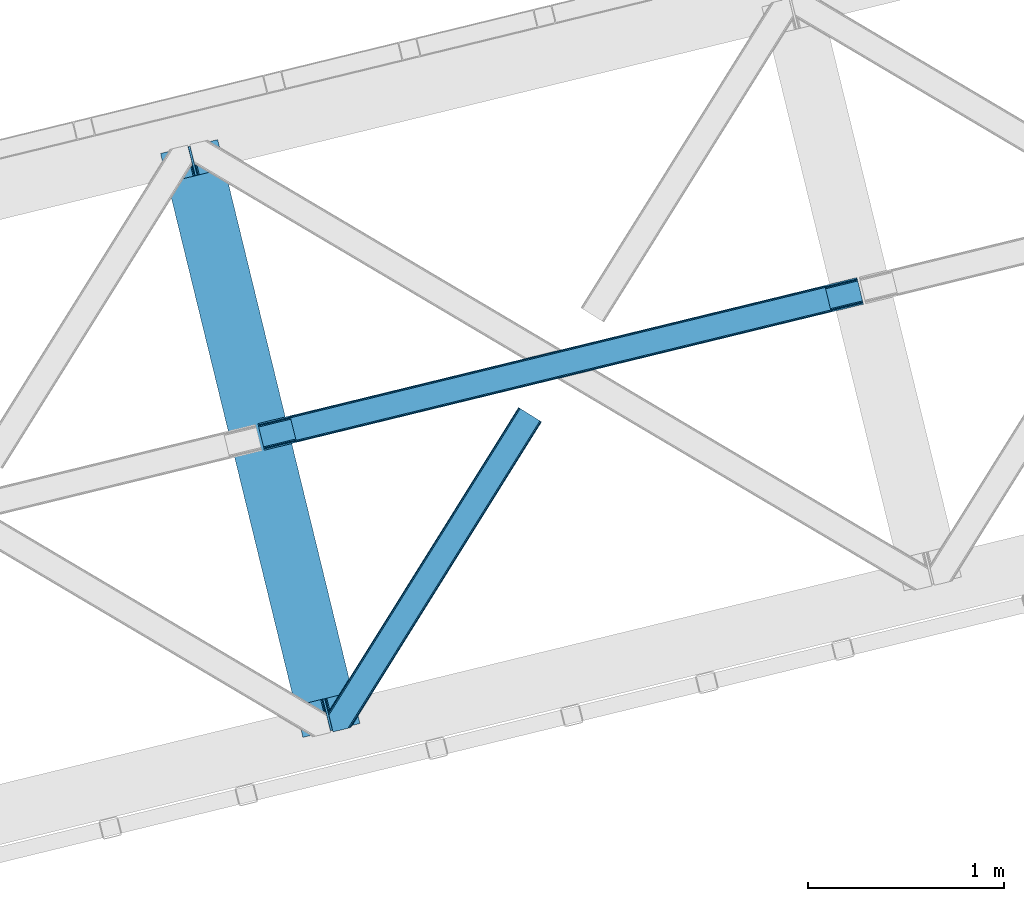
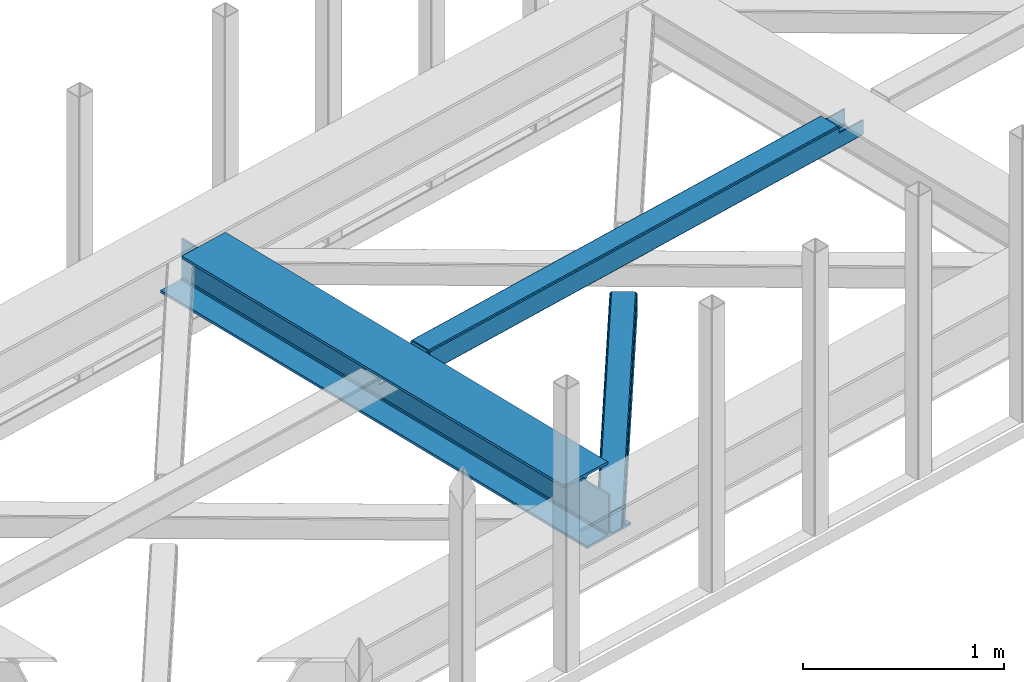
# One storey, part 46 of 67: 2 beams, 1 member.
"""IFC4 building model written with IfcOpenShell, lengths in millimetres."""

from ifc_helpers import new_model, entity, si_unit, converted_unit, derived_unit, direction, frame, origin, place, context, subcontext, project, spatial, triangles, polygons, material, type_object, element, save


model = new_model("IFC4")

# Units and contexts
model_context = context("Model", 3, precision=0.01, world=origin(), true_north=direction((6.12303176911189e-17, 1.0)))
plan_context = context("Plan", 3, precision=0.01, world=origin(), true_north=direction((6.12303176911189e-17, 1.0)))
body_context = subcontext(model_context, "Body", "Model", "MODEL_VIEW")
ifc_project = project(units=[si_unit("LENGTHUNIT", "METRE", prefix="MILLI"), si_unit("AREAUNIT", "SQUARE_METRE"), si_unit("VOLUMEUNIT", "CUBIC_METRE"), converted_unit("PLANEANGLEUNIT", "DEGREE", entity("IfcRatioMeasure", 0.0174532925199433), si_unit("PLANEANGLEUNIT", "RADIAN"), dimensions=[0, 0, 0, 0, 0, 0, 0]), si_unit("MASSUNIT", "GRAM", prefix="KILO"), derived_unit("MASSDENSITYUNIT", [(si_unit("MASSUNIT", "GRAM", prefix="KILO"), 1), (si_unit("LENGTHUNIT", "METRE"), -3)]), derived_unit("MOMENTOFINERTIAUNIT", [(si_unit("LENGTHUNIT", "METRE"), 4)]), si_unit("TIMEUNIT", "SECOND"), si_unit("FREQUENCYUNIT", "HERTZ"), si_unit("THERMODYNAMICTEMPERATUREUNIT", "DEGREE_CELSIUS"), derived_unit("THERMALTRANSMITTANCEUNIT", [(si_unit("MASSUNIT", "GRAM", prefix="KILO"), 1), (si_unit("THERMODYNAMICTEMPERATUREUNIT", "KELVIN"), -1), (si_unit("TIMEUNIT", "SECOND"), -3)]), derived_unit("VOLUMETRICFLOWRATEUNIT", [(si_unit("LENGTHUNIT", "METRE"), 3), (si_unit("TIMEUNIT", "SECOND"), -1)]), derived_unit("MASSFLOWRATEUNIT", [(si_unit("MASSUNIT", "GRAM", prefix="KILO"), 1), (si_unit("TIMEUNIT", "SECOND"), -1)]), derived_unit("ROTATIONALFREQUENCYUNIT", [(si_unit("TIMEUNIT", "SECOND"), -1)]), si_unit("ELECTRICCURRENTUNIT", "AMPERE"), si_unit("ELECTRICVOLTAGEUNIT", "VOLT"), si_unit("POWERUNIT", "WATT"), si_unit("FORCEUNIT", "NEWTON", prefix="KILO"), si_unit("ILLUMINANCEUNIT", "LUX"), si_unit("LUMINOUSFLUXUNIT", "LUMEN"), si_unit("LUMINOUSINTENSITYUNIT", "CANDELA"), derived_unit("USERDEFINED", [(si_unit("MASSUNIT", "GRAM", prefix="KILO"), -1), (si_unit("LENGTHUNIT", "METRE"), -2), (si_unit("TIMEUNIT", "SECOND"), 3), (si_unit("LUMINOUSFLUXUNIT", "LUMEN"), 1)]), derived_unit("LINEARVELOCITYUNIT", [(si_unit("LENGTHUNIT", "METRE"), 1), (si_unit("TIMEUNIT", "SECOND"), -1)]), si_unit("PRESSUREUNIT", "PASCAL"), derived_unit("USERDEFINED", [(si_unit("LENGTHUNIT", "METRE"), -2), (si_unit("MASSUNIT", "GRAM", prefix="KILO"), 1), (si_unit("TIMEUNIT", "SECOND"), -2)]), derived_unit("LINEARFORCEUNIT", [(si_unit("MASSUNIT", "GRAM", prefix="KILO"), 1), (si_unit("LENGTHUNIT", "METRE"), 1), (si_unit("TIMEUNIT", "SECOND"), -2), (si_unit("LENGTHUNIT", "METRE"), -1)]), derived_unit("PLANARFORCEUNIT", [(si_unit("MASSUNIT", "GRAM", prefix="KILO"), 1), (si_unit("LENGTHUNIT", "METRE"), 1), (si_unit("TIMEUNIT", "SECOND"), -2), (si_unit("LENGTHUNIT", "METRE"), -2)])], contexts=[model_context, plan_context])

# Site, building, storey
site_placement = place(None, origin())
site = spatial("IfcSite", under=ifc_project, at=site_placement, CompositionType="ELEMENT")
building_placement = place(site_placement, origin())
building = spatial("IfcBuilding", under=site, at=building_placement, CompositionType="ELEMENT")
storey_placement = place(building_placement, frame((0.0, 0.0, 19800.0)))
storey = spatial("IfcBuildingStorey", under=building, at=storey_placement, CompositionType="ELEMENT", Elevation=19800.0)

# Beams
ifc_material = material(Name="Metal painted (White)")
beam_type = type_object("IfcBeamType", PredefinedType="BEAM")
beam_1_placement = place(storey_placement, frame((-18024.6116349048, 13401.2394300083, 3807.02022389142)))
element("IfcBeam", 1, at=beam_1_placement, inside=storey, type_object=beam_type, material=ifc_material, ObjectType="Steel Beam", PredefinedType="BEAM", context=body_context, shape_type="Tessellation", body=[
    polygons([(1018.1664837833, 71.0478278971021, 15.5000000000008), (1018.1664837833, 71.0478278971021, 0.0), (291.465617442448, 3052.25531830422, 0.0), (291.465617442448, 3052.25531830422, 15.5000000000008), (894.779372399336, 40.9709140873291, 15.5000000000008), (168.078506058485, 3022.17840449444, 15.5000000000008), (888.087028625368, 39.3395844888221, 16.8701684148028), (161.38616228452, 3020.54707489593, 16.8701684148028), (882.413533524757, 37.956610033654, 20.7720779386434), (155.712667183904, 3019.16410044077, 20.7720779386434), (878.622625296178, 37.0325360459162, 26.6116982174338), (151.921758955329, 3018.24002645303, 26.6116982174338), (877.291435352781, 36.7080444135007, 33.500000000001), (150.59056901193, 3017.91553482062, 33.500000000001), (140.875048430516, 3015.54727389071, 33.500000000001), (140.875048430516, 3015.54727389071, 259.000000000002), (150.59056901193, 3017.91553482062, 259.000000000002), (8.66293703438714e-12, 2981.20749040711, 0.0), (6.49720277579036e-12, 2981.20749040711, 15.4999999999965), (123.38711138397, 3011.28440421689, 15.5000000000008), (130.079455157935, 3012.91573381539, 16.8701684147984), (135.752950258553, 3014.29870827056, 20.7720779386434), (139.543858487119, 3015.22278225829, 26.6116982174294), (877.291435352781, 36.7080444135007, 259.000000000002), (867.575914771367, 34.3397834835992, 259.000000000002), (867.575914771369, 34.3397834835992, 33.500000000001), (866.24472482797, 34.0152918511837, 26.6116982174294), (862.453816599406, 33.0912178634546, 20.7720779386434), (856.780321498788, 31.7082434082822, 16.8701684147984), (850.087977724821, 30.0769138097752, 15.5000000000008), (726.700866340857, 0.0, 15.4999999999965), (726.700866340857, 0.0, 0.0), (838.124523615912, 197.385937999183, 259.069791973884), (186.469722099971, 2870.72539801219, 259.000000000002), (186.693115201822, 2869.80895360721, 259.617303331124), (186.705504045448, 2869.75812937344, 266.500003008253), (837.979344808145, 197.981416001708, 266.500002998871), (837.979694928899, 197.979979696973, 260.000004007589), (828.499586345876, 194.645865944434, 259.006343171919), (828.276216326111, 195.562317481914, 259.617303331124), (828.263827482484, 195.613141715689, 266.500003008253), (176.989986719784, 2867.38985508742, 266.500002998871), (176.989636599034, 2867.39129139215, 260.000004007589), (176.844830940692, 2867.98534020594, 259.07612046749), (176.754201518561, 2868.35713708228, 259.000000000002), (839.310832678068, 198.304685446393, 273.388305639783), (843.10110926677, 199.231350618306, 279.227924098781), (848.774180214294, 200.616065081981, 283.12983240061), (855.46637189544, 202.248018612798, 284.500000377228), (978.853400583278, 232.325271667905, 284.500000138971), (978.851730776626, 232.332121736639, 299.999995328161), (687.386308679356, 161.283492472598, 299.999995890962), (687.387978486005, 161.276642403863, 284.500000701776), (810.775007173849, 191.353895458974, 284.500000463519), (817.467494070001, 192.984637925557, 283.129832461069), (823.141405718761, 194.365903570083, 279.227924137322), (826.93294050574, 195.287407219375, 273.388305663684), (175.658498849859, 2867.06658564273, 273.388305639788), (171.868222261176, 2866.13992047082, 279.227924098781), (166.195151313642, 2864.75520600715, 283.129832400619), (159.502959632499, 2863.12325247633, 284.500000377228), (36.115930944662, 2833.04599942122, 284.500000138971), (36.1176007513137, 2833.03914935249, 299.999995328161), (327.583022848584, 2904.08777861653, 299.999995890962), (327.581353041935, 2904.09462868526, 284.500000701776), (204.19432435409, 2874.01737563015, 284.500000463519), (197.501837457939, 2872.38663316357, 283.12983246106), (191.827925809187, 2871.00536751904, 279.227924137322), (188.036391022187, 2870.08386386975, 273.388305663684)], [[[1, 2, 3, 4]], [[5, 1, 4, 6]], [[7, 5, 6, 8]], [[9, 7, 8, 10]], [[11, 9, 10, 12]], [[13, 11, 12, 14]], [[15, 16, 17, 14, 12, 10, 8, 6, 4, 3, 18, 19, 20, 21, 22, 23]], [[13, 24, 25, 26, 27, 28, 29, 30, 31, 32, 2, 1, 5, 7, 9, 11]], [[2, 32, 18, 3]], [[32, 31, 19, 18]], [[31, 30, 20, 19]], [[27, 26, 15, 23]], [[28, 27, 23, 22]], [[29, 28, 22, 21]], [[30, 29, 21, 20]], [[33, 24, 13, 14, 17, 34, 35, 36, 37, 38]], [[25, 39, 40, 41, 42, 43, 44, 16, 15, 26]], [[39, 25, 24, 33]], [[45, 34, 17, 16]], [[41, 40, 38, 37, 46, 47, 48, 49, 50, 51, 52, 53, 54, 55, 56, 57]], [[42, 58, 59, 60, 61, 62, 63, 64, 65, 66, 67, 68, 69, 36, 35, 43]], [[46, 37, 36, 69]], [[47, 46, 69, 68]], [[48, 47, 68, 67]], [[49, 48, 67, 66]], [[50, 49, 66, 65]], [[51, 50, 65, 64]], [[52, 51, 64, 63]], [[53, 52, 63, 62]], [[54, 53, 62, 61]], [[55, 54, 61, 60]], [[56, 55, 60, 59]], [[57, 56, 59, 58]], [[41, 57, 58, 42]]], closed=False),
])
beam_2_placement = place(storey_placement, frame((-17527.8754833013, 14867.3373780409, 3967.02022389142)))
element("IfcBeam", 2, at=beam_2_placement, inside=storey, type_object=beam_type, material=ifc_material, ObjectType="Steel Beam", PredefinedType="BEAM", context=body_context, shape_type="Tessellation", body=[
    polygons([(31.1823923917571, 8.09507685195891, 17.8030399336114), (31.4978703677165, 6.80086440699001, 24.4999999999988), (3089.94374939708, 752.32940514057, 24.4999999999988), (3089.62827142111, 753.623617585539, 17.8030399336114), (30.2839871259056, 11.7806820741885, 12.1256313292298), (3088.72986615526, 757.309222807769, 12.1256313292298), (28.9394286278213, 17.2965800886753, 8.33210818105214), (3087.38530765717, 762.825120822256, 8.33210818105214), (27.353413740384, 23.8030254244661, 7.00000000000274), (3085.79929276974, 769.331566158046, 7.00000000000274), (4.21622439083043, 118.720708051131, 8.33210818105214), (5.8022392782634, 112.214262715343, 7.00000000000274), (3064.24811830762, 857.742803448923, 7.00000000000274), (3062.66210342018, 864.249248784712, 8.33210818105214), (2.87166589274607, 124.236606065618, 12.1256313292342), (3061.3175449221, 869.765146799198, 12.1256313292342), (1.9732606268946, 127.922211287848, 17.8030399336114), (3060.41913965625, 873.450752021428, 17.8030399336114), (1.65778265093302, 129.216423732814, 24.4999999999988), (3060.10366168029, 874.744964466399, 24.4999999999988), (33.1556530186517, -2.16573425859679e-12, 17.5000000000004), (33.1556530186517, -2.16573425859679e-12, 99.499999999999), (31.4978703677165, 6.80086440699001, 99.499999999999), (1.65778265093302, 129.216423732814, 99.499999999999), (2.16573425859679e-12, 136.017288139807, 99.499999999999), (2.16573425859679e-12, 136.017288139807, 17.5000000000004), (0.315477975961585, 134.723075694836, 10.803039933613), (1.21388324181306, 131.037470472612, 5.12563132923143), (2.55844173989742, 125.521572458121, 1.33210818105373), (4.14445662733471, 119.015127122331, 0.0), (29.011196391317, 17.0021610174739, 0.0), (30.5972112787521, 10.4957156816831, 1.33210818105373), (31.9417697768386, 4.97981766719418, 5.12563132923576), (32.8401750426901, 1.29421244496674, 10.803039933613), (3058.44587902937, 881.545828873391, 17.5000000000004), (3058.44587902937, 881.545828873391, 99.499999999999), (3060.1036616803, 874.744964466399, 99.499999999999), (3089.94374939708, 752.329405140575, 99.499999999999), (3091.60153204801, 745.528540733585, 99.499999999999), (3091.60153204801, 745.528540733585, 17.5000000000004), (3091.28605407205, 746.822753178554, 10.803039933613), (3090.3876488062, 750.508358400777, 5.12563132923576), (3089.04309030812, 756.024256415266, 1.33210818105373), (3087.45707542068, 762.530701751061, 0.0), (3062.5903356567, 864.543667855915, 0.0), (3061.00432076926, 871.050113191704, 1.33210818105373), (3059.65976227118, 876.566011206193, 5.12563132923143), (3058.76135700532, 880.251616428422, 10.803039933613), (2925.75994180942, 712.307865540883, 115.5000123926), (2925.81630989428, 712.321604759499, 100.117303289864), (2926.72300362931, 712.542621518195, 99.499999999999), (194.71860658079, 46.5876811586714, 99.5063429816656), (195.631369831906, 46.8101414944987, 100.117301735448), (195.690168193625, 46.8244741223546, 115.5), (2928.38078628024, 705.741757111203, 99.499999999999), (2927.47422618798, 705.520772937694, 100.117303484932), (2927.41464342032, 705.506249905351, 122.500007895425), (197.345360928041, 40.0229783796023, 122.500002534479), (197.338587096728, 40.0213271441435, 100.500009163303), (196.74820519572, 39.8773799905065, 99.5697919021647), (2896.88292546721, 834.958147714713, 99.5063429816656), (2895.97381660773, 834.736577551997, 100.117299778624), (2895.91744852288, 834.722838333381, 115.50000888136), (165.850080476841, 169.240033448181, 115.5), (165.840462203332, 169.237688832039, 100.50000941238), (165.250325295035, 169.093836777331, 99.5761204674868), (2894.85332685228, 841.668448882883, 99.5697919021647), (163.220745767762, 175.804071762182, 99.499999999999), (164.133244938506, 176.026503182397, 100.117301984524), (164.189439987621, 176.040201208966, 122.500002796667), (2894.25631754637, 841.522886341462, 122.500003994045), (2894.26642083519, 841.525349756029, 100.500018741102), (2894.56843170075, 840.227853719298, 129.196959150505), (2895.46176722634, 836.541012377604, 134.874360354937), (2896.8030582304, 831.024317672799, 138.667878733795), (2898.38810531641, 824.517636364724, 139.999985502214), (2923.25885436334, 722.505647815414, 139.999991354283), (2924.84634848092, 715.999563150009, 138.667885332354), (2926.19460804136, 710.484567539777, 134.874367586349), (2927.09837274857, 706.800269072827, 129.196966804773), (2925.44675217772, 713.602635936897, 122.196975799125), (2924.54298747051, 717.286934403856, 127.874376580702), (2923.19472791008, 722.801930014081, 131.667894326702), (2921.60723379249, 729.308014679486, 133.000000348631), (2900.05258461849, 817.718404755554, 132.999995276841), (2898.46753753248, 824.22508606363, 131.667888508414), (2897.12624652841, 829.741780768439, 127.874370129564), (2896.23291100282, 833.428622110128, 122.196968925133), (164.878528418698, 169.003207355192, 99.499999999999), (193.131726453727, 57.3201898040377, 131.667891818946), (191.545711566292, 63.8266351398307, 133.0), (194.476284951809, 51.8042917895488, 127.874368670764), (195.374690217663, 48.1186865673235, 122.196960066391), (169.994537104169, 152.237872430705, 133.0), (166.165558452801, 167.945821003215, 122.196960066391), (167.063963718652, 164.260215780989, 127.874368670764), (168.408522216734, 158.7443177665, 131.667891818946), (197.031411944058, 41.3175635421116, 129.196961104604), (196.136488323051, 45.0040174738959, 134.874366301861), (194.7942441573, 50.5204796458664, 138.667887185257), (193.209023953569, 57.0271186991972, 139.999994588639), (168.341882306926, 159.039986838386, 139.999994981919), (166.755021471176, 165.546225960032, 138.667887628704), (165.408105180718, 171.061549222925, 134.874366787843), (164.506189230952, 174.746298656824, 129.196961619)], [[[1, 2, 3, 4]], [[5, 1, 4, 6]], [[7, 5, 6, 8]], [[9, 7, 8, 10]], [[11, 12, 13, 14]], [[15, 11, 14, 16]], [[17, 15, 16, 18]], [[19, 17, 18, 20]], [[12, 9, 10, 13]], [[21, 22, 23, 2, 1, 5, 7, 9, 12, 11, 15, 17, 19, 24, 25, 26, 27, 28, 29, 30, 31, 32, 33, 34]], [[35, 36, 37, 20, 18, 16, 14, 13, 10, 8, 6, 4, 3, 38, 39, 40, 41, 42, 43, 44, 45, 46, 47, 48]], [[49, 50, 51, 38, 3, 2, 23, 52, 53, 54]], [[55, 39, 38, 51]], [[39, 55, 56, 57, 58, 59, 60, 22, 21, 40]], [[32, 31, 44, 43]], [[33, 32, 43, 42]], [[34, 33, 42, 41]], [[21, 34, 41, 40]], [[31, 30, 45, 44]], [[27, 26, 35, 48]], [[28, 27, 48, 47]], [[29, 28, 47, 46]], [[30, 29, 46, 45]], [[20, 37, 61, 62, 63, 64, 65, 66, 24, 19]], [[67, 36, 35, 26, 25, 68, 69, 70, 71, 72]], [[36, 67, 61, 37]], [[72, 71, 73, 74, 75, 76, 77, 78, 79, 80, 57, 56, 50, 49, 81, 82, 83, 84, 85, 86, 87, 88, 63, 62]], [[60, 52, 23, 22]], [[25, 24, 89, 68]], [[90, 91, 84, 83]], [[92, 90, 83, 82]], [[93, 92, 82, 81]], [[54, 93, 81, 49]], [[94, 85, 84, 91]], [[95, 64, 63, 88]], [[96, 95, 88, 87]], [[97, 96, 87, 86]], [[94, 97, 86, 85]], [[65, 64, 95, 96, 97, 94, 91, 90, 92, 93, 54, 53, 59, 58, 98, 99, 100, 101, 102, 103, 104, 105, 70, 69]], [[98, 58, 57, 80]], [[99, 98, 80, 79]], [[100, 99, 79, 78]], [[101, 100, 78, 77]], [[77, 76, 102, 101]], [[103, 102, 76, 75]], [[104, 103, 75, 74]], [[105, 104, 74, 73]], [[70, 105, 73, 71]]], closed=False),
])

# Member
member_type = type_object("IfcMemberType", PredefinedType="BRACE")
member_placement = place(storey_placement, frame((-17168.7764556885, 13429.4407470703, 3822.99993896484)))
element("IfcMember", 3, at=member_placement, inside=storey, type_object=member_type, ObjectType="Steel Horizontal Brace", PredefinedType="BRACE", context=body_context, shape_type="Tessellation", body=[
    triangles([(986.15143432617, 1647.42967529297, 0.0), (1075.22041625976, 1591.82725524902, 0.0), (119.789199829102, 259.603921508788, 0.0), (154.548706054688, 117.003323364257, 0.0), (115.903390502928, 275.544808959959, 4.52065429687718), (117.571893310545, 268.698715209961, 1.33247680664135), (158.434515380857, 101.062435913085, 4.52065429687718), (156.76601257324, 107.908529663086, 1.33247680664135), (114.825549316403, 275.743634033202, 5.52059326172093), (115.126693725586, 275.922692871092, 5.35316162109302), (158.127557373045, 99.1206939697258, 5.27642211914281), (115.440628051758, 276.107565307617, 5.18107910156323), (158.231039428709, 99.7776306152336, 5.02062377929906), (158.183367919919, 99.4811370849602, 5.13457031250073), (115.540621948239, 276.16686401367, 5.12526855468968), (115.682473754881, 275.92036743164, 4.88574829101708), (158.334521484372, 100.433404541014, 4.76482543945531), (158.032214355466, 98.4928253173821, 5.52059326172093), (1085.71744995117, 1585.27416687012, 5.12526855468968), (1080.90030212402, 1588.27979736328, 1.33247680664135), (1088.93469543457, 1583.26498718262, 10.8039916992202), (114.209307861325, 21.8533172607422, 10.8039916992202), (109.46541137695, 20.6964111328125, 5.52059326172093), (1090.06485900879, 1582.55921630859, 17.5012573242202), (116.061520385741, 22.304452514647, 17.5012573242202), (6.75075073241896, 102.619317626952, 5.52059326172093), (31.3608764648416, 1.65803833007703, 5.52059326172093), (1090.06485900879, 1582.55921630859, 122.499499511719), (116.061520385741, 22.304452514647, 122.499499511719), (1088.93469543457, 1583.26498718262, 129.196765136719), (114.209307861325, 21.8533172607422, 129.196765136719), (1085.71744995117, 1585.27416687012, 134.87548828125), (108.931723022459, 20.566186523436, 134.87548828125), (1080.90030212402, 1588.27979736328, 138.668280029298), (101.038018798827, 18.6418853759751, 138.668280029298), (1075.22041625976, 1591.82725524902, 140.00075683594), (91.7292846679666, 16.3734191894528, 140.00075683594), (980.470385742186, 1650.97597045898, 1.33247680664135), (975.654400634765, 1653.98160095215, 5.12526855468968), (1.68826904296657, 100.410150146483, 10.9621215820334), (972.43599243164, 1655.99078063965, 10.8039916992202), (971.306991577147, 1656.69655151367, 17.5012573242202), (0.239520263668965, 99.7776306152336, 12.5201660156272), (0.0, 100.760128784179, 17.5012573242202), (5.79266967773219, 76.9941375732415, 140.00075683594), (986.15143432617, 1647.42967529297, 140.00075683594), (24.5612915039055, 0.0, 140.00075683594), (971.306991577147, 1656.69655151367, 122.499499511719), (0.0, 100.760128784179, 122.499499511719), (980.470385742186, 1650.97597045898, 138.668280029298), (3.57536315917969, 86.088931274413, 138.668280029298), (975.654400634765, 1653.98160095215, 134.87548828125), (1.69640808105396, 93.7989257812496, 134.87548828125), (972.43599243164, 1655.99078063965, 129.196765136719), (0.44067077636646, 98.950936889647, 129.196765136719), (29.9249176025369, 1.30689697265552, 6.99957275390625), (12.1969299316406, 74.0326904296871, 6.99957275390625), (8.99131164550636, 81.5473480224609, 8.3320495605476), (3.88697204589698, 84.812265014647, 12.5201660156272), (1069.28124389648, 1595.53284301758, 6.99957275390625), (81.9961578369112, 14.000308227538, 6.99957275390625), (992.090606689451, 1643.72292480469, 6.99957275390625), (981.588922119139, 1650.27485046387, 12.1248413085959), (978.370513916014, 1652.28286743164, 17.8035644531265), (2.75797119140407, 89.4445404052731, 17.8035644531265), (986.406069946288, 1647.26805725098, 8.3320495605476), (977.241513061523, 1652.98863830566, 24.5008300781265), (2.31730041503761, 91.2537322998032, 24.5008300781265), (977.241513061523, 1652.98863830566, 115.499926757813), (2.31730041503761, 91.2537322998032, 115.499926757813), (4.01370849609157, 84.2925292968739, 127.873590087893), (2.75797119140407, 89.4445404052731, 122.197192382813), (5.89266357421729, 76.5825347900391, 131.668707275392), (8.10997009277344, 67.4865783691403, 133.001184082033), (24.5612915039055, 0.0, 133.001184082033), (978.370513916014, 1652.28286743164, 122.197192382813), (981.588922119139, 1650.27485046387, 127.873590087893), (986.406069946288, 1647.26805725098, 131.668707275392), (992.090606689451, 1643.72292480469, 133.001184082033), (1069.28124389648, 1595.53284301758, 133.001184082033), (81.9961578369112, 14.000308227538, 133.001184082033), (1079.77711486816, 1588.97975463867, 12.1248413085959), (1082.99552307129, 1586.9717376709, 17.8035644531265), (1084.12568664551, 1586.26596679687, 24.5008300781265), (1074.96112976074, 1591.98654785156, 8.3320495605476), (1079.77711486816, 1588.97975463867, 127.873590087893), (1084.12568664551, 1586.26596679687, 115.499926757813), (1082.99552307129, 1586.9717376709, 122.197192382813), (1074.96112976074, 1591.98654785156, 131.668707275392), (91.3048919677713, 16.2699371337876, 131.668707275392), (99.1985961914033, 18.1942382812485, 127.873590087893), (104.476181030273, 19.4802062988274, 122.197192382813), (106.329556274413, 19.931341552734, 115.499926757813), (91.3048919677713, 16.2699371337876, 8.3320495605476), (104.476181030273, 19.4802062988274, 17.8035644531265), (99.1985961914033, 18.1942382812485, 12.1248413085959), (106.329556274413, 19.931341552734, 24.5008300781265)], [[1, 2, 3], [4, 3, 2], [5, 3, 4], [3, 5, 6], [4, 7, 5], [7, 4, 8], [9, 10, 11], [10, 12, 13], [13, 14, 10], [12, 15, 16], [16, 17, 12], [16, 5, 7], [7, 17, 16], [17, 13, 12], [14, 11, 10], [11, 18, 9], [19, 14, 13], [13, 20, 19], [13, 17, 20], [17, 7, 20], [7, 8, 20], [21, 22, 18], [18, 19, 21], [14, 19, 11], [18, 11, 19], [22, 23, 18], [21, 24, 25], [25, 22, 21], [2, 20, 4], [8, 4, 20], [23, 26, 18], [23, 27, 26], [9, 18, 26], [24, 28, 29], [29, 25, 24], [28, 30, 29], [31, 29, 30], [30, 32, 31], [33, 31, 32], [32, 34, 33], [35, 33, 34], [34, 36, 35], [37, 35, 36], [38, 6, 5], [5, 39, 38], [5, 15, 39], [40, 41, 9], [41, 39, 15], [42, 41, 40], [40, 43, 42], [43, 44, 42], [9, 26, 40], [38, 1, 6], [3, 6, 1], [36, 45, 37], [36, 46, 45], [45, 47, 37], [48, 42, 44], [44, 49, 48], [46, 50, 51], [51, 45, 46], [50, 52, 53], [53, 51, 50], [52, 54, 55], [55, 53, 52], [54, 48, 49], [49, 55, 54], [27, 56, 57], [26, 57, 58], [57, 26, 27], [59, 40, 26], [26, 58, 59], [43, 40, 59], [60, 57, 61], [60, 62, 57], [57, 56, 61], [63, 64, 65], [65, 59, 63], [66, 63, 59], [62, 66, 58], [58, 57, 62], [59, 58, 66], [64, 67, 68], [68, 65, 64], [67, 69, 70], [70, 68, 67], [71, 53, 72], [73, 74, 45], [74, 47, 45], [74, 75, 47], [51, 73, 45], [71, 51, 53], [71, 73, 51], [49, 68, 70], [55, 72, 53], [70, 72, 49], [72, 55, 49], [44, 68, 49], [43, 59, 65], [65, 68, 44], [44, 43, 65], [69, 76, 70], [72, 70, 76], [76, 77, 72], [71, 72, 77], [77, 78, 71], [73, 71, 78], [78, 79, 73], [74, 73, 79], [80, 74, 79], [74, 80, 81], [75, 74, 81], [21, 82, 83], [84, 28, 24], [21, 83, 24], [21, 19, 82], [83, 84, 24], [82, 19, 20], [60, 2, 1], [2, 85, 20], [85, 2, 60], [85, 82, 20], [30, 86, 32], [87, 28, 84], [28, 88, 30], [88, 28, 87], [30, 88, 86], [36, 80, 46], [34, 32, 86], [86, 89, 34], [89, 80, 36], [36, 34, 89], [63, 38, 39], [1, 62, 60], [1, 66, 62], [66, 1, 38], [63, 66, 38], [67, 42, 48], [41, 64, 63], [39, 41, 63], [64, 41, 42], [67, 64, 42], [50, 77, 52], [46, 80, 79], [79, 78, 46], [78, 77, 50], [50, 46, 78], [54, 52, 77], [48, 69, 67], [76, 48, 54], [48, 76, 69], [76, 54, 77], [35, 37, 90], [47, 81, 37], [81, 47, 75], [81, 90, 37], [91, 35, 90], [91, 33, 35], [33, 92, 31], [92, 33, 91], [29, 92, 93], [92, 29, 31], [61, 23, 94], [95, 96, 23], [96, 94, 23], [61, 27, 23], [27, 61, 56], [97, 95, 25], [22, 25, 95], [29, 97, 25], [97, 29, 93], [95, 23, 22], [80, 89, 90], [90, 81, 80], [89, 86, 91], [91, 90, 89], [86, 88, 92], [92, 91, 86], [88, 87, 93], [93, 92, 88], [87, 84, 93], [97, 93, 84], [84, 83, 97], [95, 97, 83], [83, 82, 95], [96, 95, 82], [82, 85, 96], [94, 96, 85], [85, 60, 94], [61, 94, 60]]),
])

save(model, "model.ifc")
